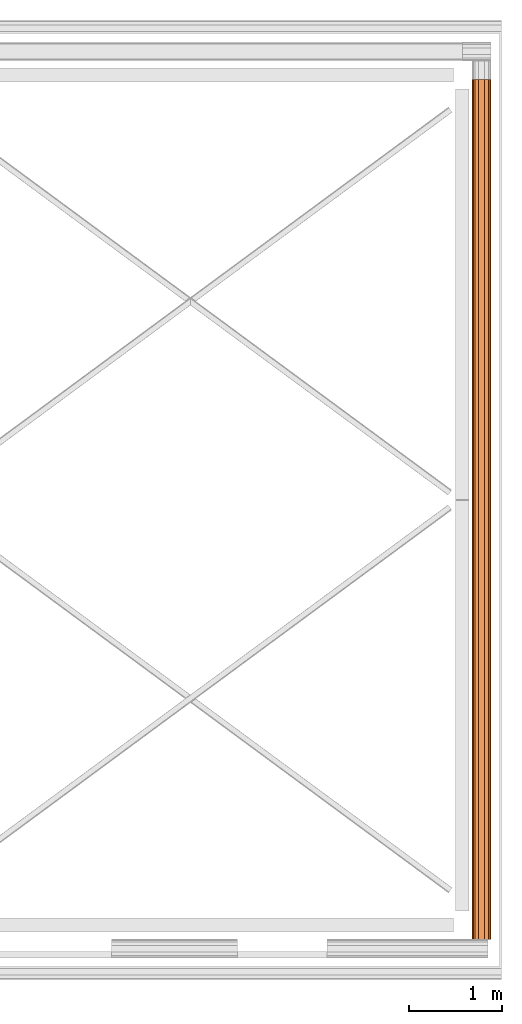
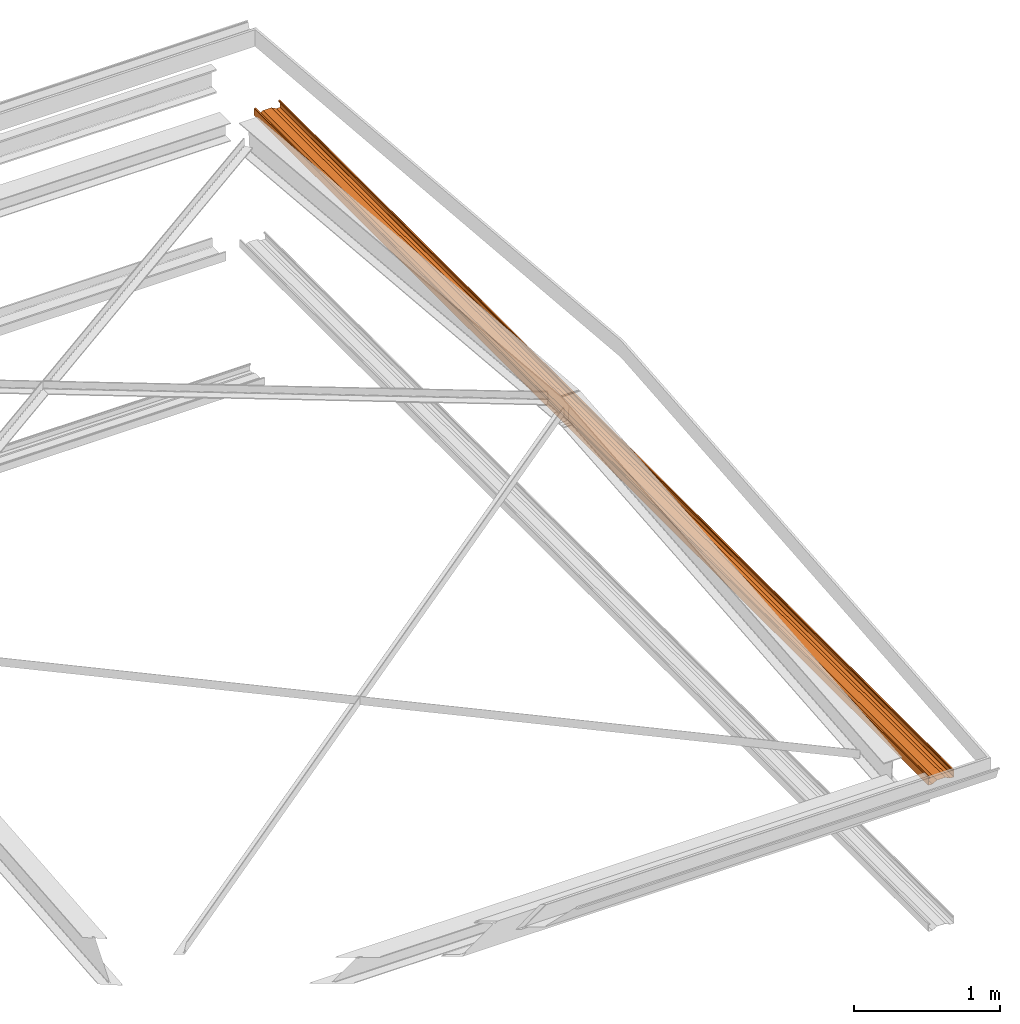
# One storey, part 8 of 8: 1 proxy.
"""IFC2X3 building model written with IfcOpenShell, lengths in millimetres."""

import ifcopenshell
import ifcopenshell.guid

model = None  # the IFC model being written
_history = None  # IfcOwnerHistory: only IFC2X3 demands one
_inside = {}  # id of a spatial element -> (the spatial element, [elements in it])
_under = {}  # id of a project, library or spatial element -> (it, [spatial elements below it])
_declared = {}  # id of a project -> (the project, [libraries it declares])
_typed = {}  # id of a type object -> (the type object, [elements of that type])
_made_of = {}  # id of a material, layer set ... -> (it, [elements and type objects made of it])


def new_model(schema):
    """Start an empty IFC model of exactly this schema.

    Asked for "IFC4X3", IfcOpenShell would pick the latest addendum, in which some entities
    have other attributes; the version numbers below select the first issue.
    IFC2X3 requires an IfcOwnerHistory on every rooted entity: one is made here for all.
    """
    global model, _history
    if schema == "IFC4X3":
        model = ifcopenshell.file(schema_version=(4, 3, 0, 0))
    else:
        model = ifcopenshell.file(schema=schema)
    _inside.clear()
    _under.clear()
    _declared.clear()
    _typed.clear()
    _made_of.clear()
    _history = None
    if model.schema == "IFC2X3":
        org = make("IfcOrganization", Name="unknown")
        user = make(
            "IfcPersonAndOrganization",
            ThePerson=make("IfcPerson", FamilyName="unknown"),
            TheOrganization=org,
        )
        app = make(
            "IfcApplication",
            ApplicationDeveloper=org,
            Version="unknown",
            ApplicationFullName="unknown",
            ApplicationIdentifier="unknown",
        )
        _history = make(
            "IfcOwnerHistory",
            OwningUser=user,
            OwningApplication=app,
            ChangeAction="ADDED",
            CreationDate=0,
        )
    return model


def make(cls, **values):
    """One entity of the class cls with the attributes given. An attribute that is None is left unset."""
    return model.create_entity(
        cls, **{name: value for name, value in values.items() if value is not None}
    )


def entity(cls, *values):
    """Any entity or typed value of the class cls, its attributes in the order of the schema. None: left unset."""
    e = model.create_entity(cls)
    for i, value in enumerate(values):
        if value is not None:
            e[i] = value
    return e


def rooted(cls, **values):
    """An entity with a GlobalId (a new one), such as an element, a storey or a relation."""
    return make(cls, GlobalId=ifcopenshell.guid.new(), OwnerHistory=_history, **values)


def si_unit(unit_type, name, prefix=None):
    """IfcSIUnit, for example si_unit("LENGTHUNIT", "METRE", prefix="MILLI")."""
    return make("IfcSIUnit", UnitType=unit_type, Prefix=prefix, Name=name)


def converted_unit(unit_type, name, factor, base, dimensions=None, offset=None):
    """IfcConversionBasedUnit, such as the inch: factor (a typed value) times the base unit."""
    return make(
        "IfcConversionBasedUnit"
        if offset is None
        else "IfcConversionBasedUnitWithOffset",
        ConversionOffset=offset,
        Dimensions=None
        if dimensions is None
        else entity("IfcDimensionalExponents", *dimensions),
        UnitType=unit_type,
        Name=name,
        ConversionFactor=make(
            "IfcMeasureWithUnit", ValueComponent=factor, UnitComponent=base
        ),
    )


def money_unit(currency):
    """IfcMonetaryUnit."""
    return make("IfcMonetaryUnit", Currency=currency)


def assignment(units):
    """IfcUnitAssignment: the units of a project."""
    return None if units is None else make("IfcUnitAssignment", Units=units)


def point(xyz):
    """IfcCartesianPoint."""
    return None if xyz is None else make("IfcCartesianPoint", Coordinates=xyz)


def direction(xyz):
    """IfcDirection."""
    return None if xyz is None else make("IfcDirection", DirectionRatios=xyz)


def frame(location, z_axis=None, x_axis=None):
    """IfcAxis2Placement3D, a coordinate frame: its origin and axes. An axis left out is left unset."""
    return make(
        "IfcAxis2Placement3D",
        Location=point(location),
        Axis=direction(z_axis),
        RefDirection=direction(x_axis),
    )


def origin_with_axes():
    """The frame at (0, 0, 0) with the z axis (0, 0, 1) and the x axis (1, 0, 0) written out."""
    return frame((0.0, 0.0, 0.0), z_axis=(0.0, 0.0, 1.0), x_axis=(1.0, 0.0, 0.0))


def place(relative_to, where):
    """IfcLocalPlacement: puts the frame where relative to a parent placement (None: the world)."""
    return make(
        "IfcLocalPlacement", PlacementRelTo=relative_to, RelativePlacement=where
    )


def context(
    kind, dimensions, precision=None, world=None, true_north=None, identifier=None
):
    """IfcGeometricRepresentationContext, for example the 3D "Model" context."""
    return make(
        "IfcGeometricRepresentationContext",
        ContextIdentifier=identifier,
        ContextType=kind,
        CoordinateSpaceDimension=dimensions,
        Precision=precision,
        WorldCoordinateSystem=world,
        TrueNorth=true_north,
    )


def subcontext(parent, identifier, kind, view, scale=None):
    """IfcGeometricRepresentationSubContext, for example "Body" below "Model"."""
    return make(
        "IfcGeometricRepresentationSubContext",
        ContextIdentifier=identifier,
        ContextType=kind,
        ParentContext=parent,
        TargetScale=scale,
        TargetView=view,
    )


def project(units=None, contexts=None):
    """IfcProject with its units and contexts."""
    return rooted(
        "IfcProject",
        Name="project",
        RepresentationContexts=contexts,
        UnitsInContext=assignment(units),
    )


def spatial(cls, under=None, at=None, **own):
    """A site, building, storey or space (cls), placed at a placement, below another one or the project."""
    s = rooted(cls, ObjectPlacement=at, **own)
    if under is not None:
        _under.setdefault(under.id(), (under, []))[1].append(s)
    return s


def faces_of(points, faces, orient=None, outer=None):
    """IfcFace entities. A face is a list of loops; a loop is a list of indices into points, from 0.

    orient and outer hold one flag for each loop. By default every Orientation is true, the
    first loop of a face is its IfcFaceOuterBound and the others are IfcFaceBound.
    """
    made = []
    for i, loops in enumerate(faces):
        bounds = []
        for j, loop in enumerate(loops):
            is_outer = j == 0 if outer is None else outer[i][j]
            bounds.append(
                make(
                    "IfcFaceOuterBound" if is_outer else "IfcFaceBound",
                    Bound=make("IfcPolyLoop", Polygon=[points[k] for k in loop]),
                    Orientation=True if orient is None else orient[i][j],
                )
            )
        made.append(make("IfcFace", Bounds=bounds))
    return made


def faceted_brep(points, faces, orient=None, outer=None, voids=None):
    """IfcFacetedBrep: a solid bounded by flat faces; with voids (closed shells), ...WithVoids."""
    shared = [point(p) for p in points]
    hull = make("IfcClosedShell", CfsFaces=faces_of(shared, faces, orient, outer))
    if voids is None:
        return make("IfcFacetedBrep", Outer=hull)
    return make(
        "IfcFacetedBrepWithVoids",
        Outer=hull,
        Voids=[
            make(cls, CfsFaces=faces_of(shared, fs, o, b)) for cls, fs, o, b in voids
        ],
    )


def shape(context_of_items, identifier, shape_type, items):
    """IfcShapeRepresentation: the items that make up one representation, for example the "Body"."""
    return make(
        "IfcShapeRepresentation",
        ContextOfItems=context_of_items,
        RepresentationIdentifier=identifier,
        RepresentationType=shape_type,
        Items=items,
    )


def material(Name=None, Category=None):
    """IfcMaterial."""
    return make("IfcMaterial", Name=Name, Category=Category)


def made_of(thing, what):
    """Note that an element or type object is made of a material, layer set ...; save() writes the relation."""
    if what is not None:
        _made_of.setdefault(what.id(), (what, []))[1].append(thing)
    return thing


def type_object(cls, material=None, **own):
    """A type object (cls), such as IfcWallType, which elements share."""
    return made_of(rooted(cls, **own), material)


def element(
    cls,
    number,
    at=None,
    inside=None,
    cuts=None,
    type_object=None,
    material=None,
    context=None,
    identifier="Body",
    shape_type=None,
    held_by="IfcProductDefinitionShape",
    body=None,
    shapes=None,
    **own,
):
    """One element of the class cls, such as IfcWall. Its Tag is "e" and its number.

    at: its placement. inside: the storey or other place that contains it. cuts: it is an
    opening in that element (IfcRelVoidsElement). A single representation is given by context,
    identifier, shape_type and body (its items); several are given by shapes. held_by: the class
    of the entity that holds the representations. save() writes the other relations.
    """
    e = rooted(cls, Tag="e%d" % number, ObjectPlacement=at, **own)
    if body is not None:
        shapes = [shape(context, identifier, shape_type, body)]
    if shapes is not None:
        e.Representation = make(held_by, Representations=shapes)
    if inside is not None:
        _inside.setdefault(inside.id(), (inside, []))[1].append(e)
    if cuts is not None:
        rooted(
            "IfcRelVoidsElement", RelatingBuildingElement=cuts, RelatedOpeningElement=e
        )
    if type_object is not None:
        _typed.setdefault(type_object.id(), (type_object, []))[1].append(e)
    return made_of(e, material)


def aggregate(whole, parts):
    """IfcRelAggregates: a whole, such as a stair, and the parts it consists of."""
    return rooted("IfcRelAggregates", RelatingObject=whole, RelatedObjects=parts)


def save(model, path):
    """Write the relations noted so far, then the file.

    IfcRelAggregates (storeys below a building ...), IfcRelContainedInSpatialStructure (elements
    in a storey), IfcRelDefinesByType, IfcRelAssociatesMaterial and IfcRelDeclares: one each for
    every whole, place, type object, material and project.
    """
    for whole, parts in _under.values():
        aggregate(whole, parts)
    for where, things in _inside.values():
        rooted(
            "IfcRelContainedInSpatialStructure",
            RelatedElements=things,
            RelatingStructure=where,
        )
    for kind, things in _typed.values():
        rooted("IfcRelDefinesByType", RelatedObjects=things, RelatingType=kind)
    for what, things in _made_of.values():
        rooted("IfcRelAssociatesMaterial", RelatedObjects=things, RelatingMaterial=what)
    for by, libraries in _declared.values():
        rooted("IfcRelDeclares", RelatingContext=by, RelatedDefinitions=libraries)
    model.write(path)


model = new_model("IFC2X3")

# Units and contexts
model_context = context("Model", 3, precision=1e-05, world=origin_with_axes(), true_north=direction((0.0, 1.0)))
body_context = subcontext(model_context, "Body", "Model", "MODEL_VIEW")
ifc_project = project(units=[si_unit("LENGTHUNIT", "METRE", prefix="MILLI"), si_unit("AREAUNIT", "SQUARE_METRE"), si_unit("VOLUMEUNIT", "CUBIC_METRE"), converted_unit("PLANEANGLEUNIT", "DEGREE", entity("IfcPlaneAngleMeasure", 0.0174532925199), si_unit("PLANEANGLEUNIT", "RADIAN"), dimensions=[0, 0, 0, 0, 0, 0, 0]), si_unit("SOLIDANGLEUNIT", "STERADIAN"), money_unit("USD"), converted_unit("TIMEUNIT", "Year", entity("IfcTimeMeasure", 31556926.0), si_unit("TIMEUNIT", "SECOND"), dimensions=[0, 0, 0, 0, 0, 0, 0]), si_unit("MASSUNIT", "GRAM"), si_unit("THERMODYNAMICTEMPERATUREUNIT", "DEGREE_CELSIUS"), si_unit("LUMINOUSINTENSITYUNIT", "LUMEN")], contexts=[model_context])

# Site, building, storey
site_placement = place(None, origin_with_axes())
site = spatial("IfcSite", under=ifc_project, at=site_placement, CompositionType="ELEMENT")
building_placement = place(site_placement, origin_with_axes())
building = spatial("IfcBuilding", under=site, at=building_placement, CompositionType="ELEMENT")
storey_placement = place(building_placement, frame((0.0, 0.0, 74215.0), z_axis=(0.0, 0.0, 1.0), x_axis=(1.0, 0.0, 0.0)))
storey = spatial("IfcBuildingStorey", under=building, at=storey_placement, CompositionType="ELEMENT", Elevation=74215.0)

# Proxy
ifc_material = material(Name="Metal - Steel 43-275")
building_element_proxy_type = type_object("IfcBuildingElementProxyType", Name="M", PredefinedType="USERDEFINED")
proxy_placement = place(storey_placement, frame((16615.5295383, 3597.47992169, -65.0), z_axis=(0.0, 0.0, 1.0), x_axis=(0.0, -1.0, 0.0)))
element("IfcBuildingElementProxy", 1, at=proxy_placement, inside=storey, type_object=building_element_proxy_type, material=ifc_material, Name="Light Gauge-Kingspan Rails:M", ObjectType="M", context=body_context, shape_type="Brep", body=[
    faceted_brep([(-4501.5, 70.5, 0.0), (-4501.5, 99.3, 0.0), (4745.5, 99.3, 0.0), (4745.5, 70.5, 0.0), (-4501.5, 32.5, 20.0), (-4501.5, -32.5, 20.0), (-4501.5, -70.5, 0.0), (-4501.5, -99.3, 0.0), (-4501.5, -100.524586984, 0.24358549596), (-4501.5, -101.5627417, 0.9372583002), (-4501.5, -102.256414504, 1.97541301643), (-4501.5, -102.5, 3.2), (-4501.5, -102.5, 61.8), (-4501.5, -102.256414504, 63.0245869836), (-4501.5, -101.5627417, 64.0627416998), (-4501.5, -100.524586984, 64.756414504), (-4501.5, -99.3, 65.0), (-4501.5, -91.7, 65.0), (-4501.5, -90.4754130164, 64.756414504), (-4501.5, -89.4372583002, 64.0627416998), (-4501.5, -88.743585496, 63.0245869836), (-4501.5, -88.5, 61.8), (-4501.5, -88.5, 53.0), (-4501.5, -90.1, 53.0), (-4501.5, -90.1, 61.8), (-4501.5, -90.221792748, 62.4122934918), (-4501.5, -90.5686291501, 62.9313708499), (-4501.5, -91.0877065082, 63.278207252), (-4501.5, -91.7, 63.4), (-4501.5, -99.3, 63.4), (-4501.5, -99.9122934918, 63.278207252), (-4501.5, -100.43137085, 62.9313708499), (-4501.5, -100.778207252, 62.4122934918), (-4501.5, -100.9, 61.8), (-4501.5, -100.9, 3.2), (-4501.5, -100.778207252, 2.58770650822), (-4501.5, -100.43137085, 2.0686291501), (-4501.5, -99.9122934918, 1.72179274798), (-4501.5, -99.3, 1.6), (-4501.5, -70.8953456886, 1.6), (-4501.5, -32.8953456886, 21.6), (-4501.5, 32.8953456886, 21.6), (-4501.5, 70.8953456886, 1.6), (-4501.5, 99.3, 1.6), (-4501.5, 99.9122934918, 1.72179274798), (-4501.5, 100.43137085, 2.0686291501), (-4501.5, 100.778207252, 2.58770650822), (-4501.5, 100.9, 3.2), (-4501.5, 100.9, 61.8), (-4501.5, 100.778207252, 62.4122934918), (-4501.5, 100.43137085, 62.9313708499), (-4501.5, 99.9122934918, 63.278207252), (-4501.5, 99.3, 63.4), (-4501.5, 91.7, 63.4), (-4501.5, 91.0877065082, 63.278207252), (-4501.5, 90.5686291501, 62.9313708499), (-4501.5, 90.221792748, 62.4122934918), (-4501.5, 90.1, 61.8), (-4501.5, 90.1, 53.0), (-4501.5, 88.5, 53.0), (-4501.5, 88.5, 61.8), (-4501.5, 88.743585496, 63.0245869836), (-4501.5, 89.4372583002, 64.0627416998), (-4501.5, 90.4754130164, 64.756414504), (-4501.5, 91.7, 65.0), (-4501.5, 99.3, 65.0), (-4501.5, 100.524586984, 64.756414504), (-4501.5, 101.5627417, 64.0627416998), (-4501.5, 102.256414504, 63.0245869836), (-4501.5, 102.5, 61.8), (-4501.5, 102.5, 3.2), (-4501.5, 102.256414504, 1.97541301643), (-4501.5, 101.5627417, 0.9372583002), (-4501.5, 100.524586984, 0.24358549596), (4745.5, 100.524586984, 0.24358549596), (4745.5, 101.5627417, 0.9372583002), (4745.5, 102.256414504, 1.97541301643), (4745.5, 102.5, 3.2), (4745.5, 102.5, 61.8), (4745.5, 102.256414504, 63.0245869836), (4745.5, 101.5627417, 64.0627416998), (4745.5, 100.524586984, 64.756414504), (4745.5, 99.3, 65.0), (4745.5, 91.7, 65.0), (4745.5, 90.4754130164, 64.756414504), (4745.5, 89.4372583002, 64.0627416998), (4745.5, 88.743585496, 63.0245869836), (4745.5, 88.5, 61.8), (4745.5, 88.5, 53.0), (4745.5, 90.1, 53.0), (4745.5, 90.1, 61.8), (4745.5, 90.221792748, 62.4122934918), (4745.5, 90.5686291501, 62.9313708499), (4745.5, 91.0877065082, 63.278207252), (4745.5, 91.7, 63.4), (4745.5, 99.3, 63.4), (4745.5, 99.9122934918, 63.278207252), (4745.5, 100.43137085, 62.9313708499), (4745.5, 100.778207252, 62.4122934918), (4745.5, 100.9, 61.8), (4745.5, 100.9, 3.2), (4745.5, 100.778207252, 2.58770650822), (4745.5, 100.43137085, 2.0686291501), (4745.5, 99.9122934918, 1.72179274798), (4745.5, 99.3, 1.6), (4745.5, 70.8953456886, 1.6), (4745.5, 32.8953456886, 21.6), (4745.5, -32.8953456886, 21.6), (4745.5, -70.8953456886, 1.6), (4745.5, -99.3, 1.6), (4745.5, -99.9122934918, 1.72179274798), (4745.5, -100.43137085, 2.0686291501), (4745.5, -100.778207252, 2.58770650822), (4745.5, -100.9, 3.2), (4745.5, -100.9, 61.8), (4745.5, -100.778207252, 62.4122934918), (4745.5, -100.43137085, 62.9313708499), (4745.5, -99.9122934918, 63.278207252), (4745.5, -99.3, 63.4), (4745.5, -91.7, 63.4), (4745.5, -91.0877065082, 63.278207252), (4745.5, -90.5686291501, 62.9313708499), (4745.5, -90.221792748, 62.4122934918), (4745.5, -90.1, 61.8), (4745.5, -90.1, 53.0), (4745.5, -88.5, 53.0), (4745.5, -88.5, 61.8), (4745.5, -88.743585496, 63.0245869836), (4745.5, -89.4372583002, 64.0627416998), (4745.5, -90.4754130164, 64.756414504), (4745.5, -91.7, 65.0), (4745.5, -99.3, 65.0), (4745.5, -100.524586984, 64.756414504), (4745.5, -101.5627417, 64.0627416998), (4745.5, -102.256414504, 63.0245869836), (4745.5, -102.5, 61.8), (4745.5, -102.5, 3.2), (4745.5, -102.256414504, 1.97541301643), (4745.5, -101.5627417, 0.9372583002), (4745.5, -100.524586984, 0.24358549596), (4745.5, -99.3, 0.0), (4745.5, -70.5, 0.0), (4745.5, -32.5, 20.0), (4745.5, 32.5, 20.0)], [[[0, 1, 2, 3]], [[0, 4, 5, 6, 7, 8, 9, 10, 11, 12, 13, 14, 15, 16, 17, 18, 19, 20, 21, 22, 23, 24, 25, 26, 27, 28, 29, 30, 31, 32, 33, 34, 35, 36, 37, 38, 39, 40, 41, 42, 43, 44, 45, 46, 47, 48, 49, 50, 51, 52, 53, 54, 55, 56, 57, 58, 59, 60, 61, 62, 63, 64, 65, 66, 67, 68, 69, 70, 71, 72, 73, 1]], [[1, 73, 74, 2]], [[3, 2, 74, 75, 76, 77, 78, 79, 80, 81, 82, 83, 84, 85, 86, 87, 88, 89, 90, 91, 92, 93, 94, 95, 96, 97, 98, 99, 100, 101, 102, 103, 104, 105, 106, 107, 108, 109, 110, 111, 112, 113, 114, 115, 116, 117, 118, 119, 120, 121, 122, 123, 124, 125, 126, 127, 128, 129, 130, 131, 132, 133, 134, 135, 136, 137, 138, 139, 140, 141, 142, 143]], [[4, 0, 3, 143]], [[5, 4, 143, 142]], [[6, 5, 142, 141]], [[7, 6, 141, 140]], [[8, 7, 140, 139]], [[9, 8, 139, 138]], [[10, 9, 138, 137]], [[11, 10, 137, 136]], [[12, 11, 136, 135]], [[13, 12, 135, 134]], [[14, 13, 134, 133]], [[15, 14, 133, 132]], [[16, 15, 132, 131]], [[17, 16, 131, 130]], [[18, 17, 130, 129]], [[19, 18, 129, 128]], [[20, 19, 128, 127]], [[21, 20, 127, 126]], [[22, 21, 126, 125]], [[23, 22, 125, 124]], [[24, 23, 124, 123]], [[25, 24, 123, 122]], [[26, 25, 122, 121]], [[27, 26, 121, 120]], [[28, 27, 120, 119]], [[29, 28, 119, 118]], [[30, 29, 118, 117]], [[31, 30, 117, 116]], [[32, 31, 116, 115]], [[33, 32, 115, 114]], [[34, 33, 114, 113]], [[35, 34, 113, 112]], [[36, 35, 112, 111]], [[37, 36, 111, 110]], [[38, 37, 110, 109]], [[39, 38, 109, 108]], [[40, 39, 108, 107]], [[41, 40, 107, 106]], [[42, 41, 106, 105]], [[43, 42, 105, 104]], [[44, 43, 104, 103]], [[45, 44, 103, 102]], [[46, 45, 102, 101]], [[47, 46, 101, 100]], [[48, 47, 100, 99]], [[49, 48, 99, 98]], [[50, 49, 98, 97]], [[51, 50, 97, 96]], [[52, 51, 96, 95]], [[53, 52, 95, 94]], [[54, 53, 94, 93]], [[55, 54, 93, 92]], [[56, 55, 92, 91]], [[57, 56, 91, 90]], [[58, 57, 90, 89]], [[59, 58, 89, 88]], [[60, 59, 88, 87]], [[61, 60, 87, 86]], [[62, 61, 86, 85]], [[63, 62, 85, 84]], [[64, 63, 84, 83]], [[65, 64, 83, 82]], [[66, 65, 82, 81]], [[67, 66, 81, 80]], [[68, 67, 80, 79]], [[69, 68, 79, 78]], [[70, 69, 78, 77]], [[71, 70, 77, 76]], [[72, 71, 76, 75]], [[73, 72, 75, 74]]]),
])

save(model, "model.ifc")
